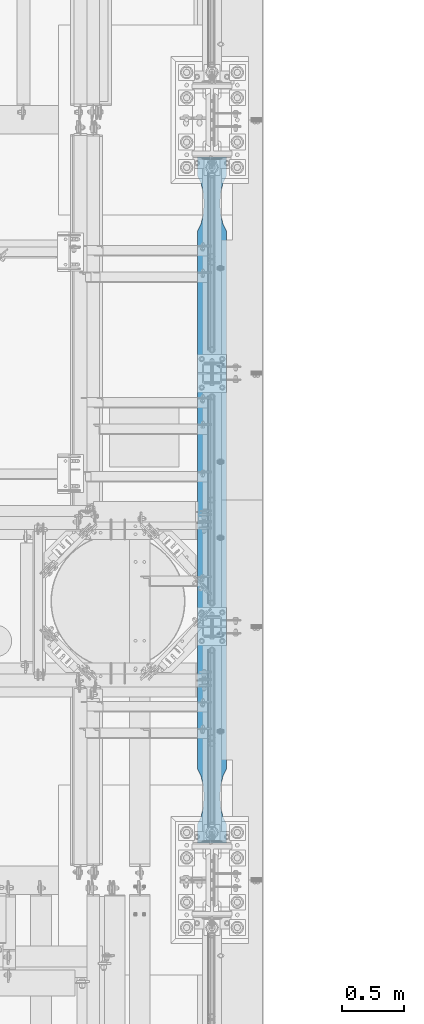
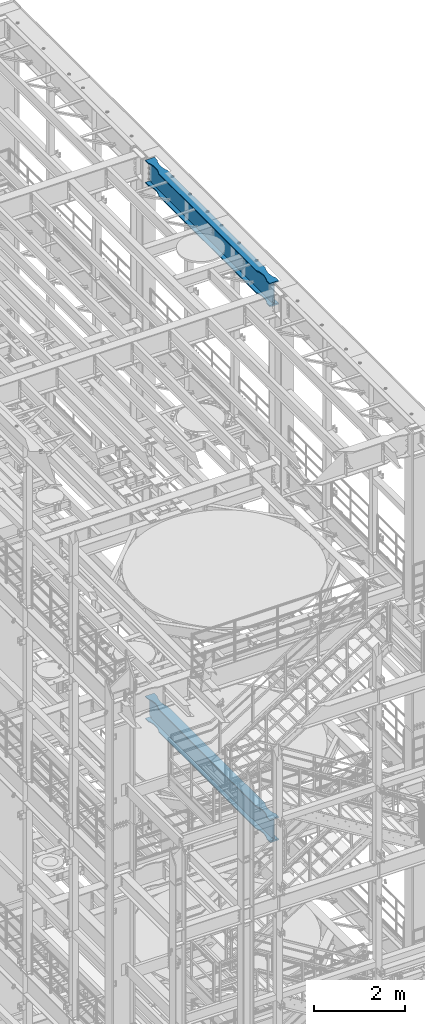
# One storey, part 1039 of 1876: 2 beams, 2 elements without a shape of their own.
"""IFC2X3 building model written with IfcOpenShell, lengths in millimetres."""

from ifc_helpers import new_model, si_unit, frame, origin_with_axes, place, context, subcontext, project, spatial, faceted_brep, material, type_object, element, aggregate, save


model = new_model("IFC2X3")

# Units and contexts
model_context = context("Model", 3, precision=1e-05, world=origin_with_axes())
body_context = subcontext(model_context, "Body", "Model", "MODEL_VIEW")
ifc_project = project(units=[si_unit("LENGTHUNIT", "METRE", prefix="MILLI"), si_unit("AREAUNIT", "SQUARE_METRE"), si_unit("VOLUMEUNIT", "CUBIC_METRE"), si_unit("MASSUNIT", "GRAM", prefix="KILO"), si_unit("TIMEUNIT", "SECOND"), si_unit("PLANEANGLEUNIT", "RADIAN"), si_unit("SOLIDANGLEUNIT", "STERADIAN"), si_unit("THERMODYNAMICTEMPERATUREUNIT", "DEGREE_CELSIUS"), si_unit("LUMINOUSINTENSITYUNIT", "LUMEN")], contexts=[model_context])

# Site, building, storey
site_placement = place(None, origin_with_axes())
site = spatial("IfcSite", under=ifc_project, at=site_placement, CompositionType="ELEMENT")
building_placement = place(site_placement, origin_with_axes())
building = spatial("IfcBuilding", under=site, at=building_placement, Name="Undefined", CompositionType="ELEMENT")
storey_placement = place(building_placement, origin_with_axes())
storey = spatial("IfcBuildingStorey", under=building, at=storey_placement, Name="Undefined", CompositionType="ELEMENT", Elevation=0.0)

# Assembly, beam
assembly_1_placement = place(storey_placement, origin_with_axes())
assembly_1 = element("IfcElementAssembly", 1, at=assembly_1_placement, inside=storey, Name="BEAM", AssemblyPlace="NOTDEFINED", PredefinedType="RIGID_FRAME")
ifc_material = material(Name="STEEL/A992")
beam_type = type_object("IfcBeamType", Name="W24X103", PredefinedType="NOTDEFINED")
beam_1_placement = place(assembly_1_placement, frame((7620.0, 1524.0, 7842.25), z_axis=(0.0, 0.0, 1.0), x_axis=(0.0, 1.0, 0.0)))
beam_1 = element("IfcBeam", 2, at=beam_1_placement, type_object=beam_type, material=ifc_material, Name="BEAM", ObjectType="W24X103", context=body_context, shape_type="Brep", body=[
    faceted_brep([(5789.6125, -7.14375000000018, -250.825000000001), (5797.55, 7.14375000000018, -250.825000000001), (5797.55, 7.14375000000018, 250.825000000001), (5789.6125, -7.14375000000018, 250.825000000001), (306.3875, -7.14375000000018, 250.825000000001), (298.45, 7.14375000000018, 250.825000000001), (298.45, 7.14375000000018, -250.825000000001), (306.3875, -7.14375000000018, -250.825000000001), (5797.55, -114.3, 285.75), (5797.55, -7.14375000000018, 285.75), (5797.55, 7.14375000000018, 285.75), (5797.55, 114.3, 285.75), (5782.88541369173, 114.29999927708, 311.150000000001), (5782.88541369173, -114.29999927708, 311.150000000001), (5641.97500876196, 114.299992330618, 311.150000000001), (5641.97500876196, 114.3, 285.75), (5592.87586146151, 88.8999957361821, 285.75), (5592.87586146151, 88.8999957361821, 311.150000000001), (5510.43685211057, 69.8863924058523, 285.75), (5510.43685211057, 69.8863924058523, 311.150000000001), (5426.0750039875, 63.5000040971918, 285.75), (5426.0750039875, 63.5000040971918, 311.150000000001), (5341.71315599965, 69.8863941921136, 285.75), (5341.71315599965, 69.8863941921136, 311.150000000001), (5259.2741470513, 88.8999992679901, 285.75), (5259.2741470513, 88.8999992679901, 311.150000000001), (5210.175, 114.3, 285.75), (5210.175, 114.3, 311.150000000001), (885.825008761703, 114.3, 285.75), (885.825008761703, 114.299990374483, 311.150000000001), (836.72586171043, 88.899989642473, 285.75), (836.72586171043, 88.899989642473, 311.150000000001), (754.286852762112, 69.8863845665965, 285.75), (754.286852762112, 69.8863845665965, 311.150000000001), (669.925004774302, 63.4999944716747, 285.75), (669.925004774302, 63.4999944716747, 311.150000000001), (585.563156651265, 69.8863827803352, 285.75), (585.563156651265, 69.8863827803352, 311.150000000001), (503.124147300347, 88.8999861106649, 285.75), (503.124147300347, 88.8999861106649, 311.150000000001), (454.024999999921, 114.3, 285.75), (454.024999999921, 114.3, 311.150000000001), (298.45, 114.3, 285.75), (313.114586308271, 114.3, 311.150000000001), (5641.97500876196, 114.299992330618, -285.75), (5641.97500876196, 114.3, -311.150000000001), (5592.87586146151, 88.8999957361821, -311.150000000001), (5592.87586146151, 88.8999957361821, -285.75), (5510.43685211057, 69.8863924058523, -311.150000000001), (5510.43685211057, 69.8863924058523, -285.75), (5426.0750039875, 63.5000040971918, -311.150000000001), (5426.0750039875, 63.5000040971918, -285.75), (5341.71315599965, 69.8863941921136, -311.150000000001), (5341.71315599965, 69.8863941921136, -285.75), (5259.2741470513, 88.8999992679901, -311.150000000001), (5259.2741470513, 88.8999992679901, -285.75), (5210.175, 114.3, -311.150000000001), (5210.175, 114.3, -285.75), (885.825008761703, 114.3, -311.150000000001), (885.825008761703, 114.299990374483, -285.75), (836.72586171043, 88.899989642473, -311.150000000001), (836.72586171043, 88.899989642473, -285.75), (754.286852762112, 69.8863845665965, -311.150000000001), (754.286852762112, 69.8863845665965, -285.75), (669.925004774302, 63.4999944716747, -311.150000000001), (669.925004774302, 63.4999944716747, -285.75), (585.563156651265, 69.8863827803352, -311.150000000001), (585.563156651265, 69.8863827803352, -285.75), (503.124147300347, 88.8999861106649, -311.150000000001), (503.124147300347, 88.8999861106649, -285.75), (454.024999999921, 114.3, -311.150000000001), (454.024999999921, 114.3, -285.75), (298.45, 114.3, -311.150000000001), (313.11459905754, 114.3, -285.75), (5641.97500876196, -114.299992330618, -285.75), (5592.87586146151, -88.8999957361821, -285.75), (5592.87586146151, -88.8999957361821, -311.150000000001), (5641.97500876196, -114.3, -311.150000000001), (5510.43685211057, -69.8863924058523, -285.75), (5510.43685211057, -69.8863924058523, -311.150000000001), (5426.0750039875, -63.5000040971918, -285.75), (5426.0750039875, -63.5000040971918, -311.150000000001), (5341.71315599965, -69.8863941921136, -285.75), (5341.71315599965, -69.8863941921136, -311.150000000001), (5259.2741470513, -88.8999992679901, -285.75), (5259.2741470513, -88.8999992679901, -311.150000000001), (5210.175, -114.3, -285.75), (5210.175, -114.3, -311.150000000001), (885.825008761703, -114.300009625517, -285.75), (885.825008761703, -114.3, -311.150000000001), (836.72586171043, -88.9000088935072, -285.75), (836.72586171043, -88.9000088935072, -311.150000000001), (754.286852762112, -69.8864038176307, -285.75), (754.286852762112, -69.8864038176307, -311.150000000001), (669.925004774302, -63.5000137227089, -285.75), (669.925004774302, -63.5000137227089, -311.150000000001), (585.563156651265, -69.8864020313695, -285.75), (585.563156651265, -69.8864020313695, -311.150000000001), (503.124147300347, -88.9000053616992, -285.75), (503.124147300347, -88.9000053616992, -311.150000000001), (454.024999999921, -114.3, -285.75), (454.024999999921, -114.3, -311.150000000001), (313.11459905754, -114.3, -285.75), (298.45, -114.3, -311.150000000001), (313.343799385621, -7.14375000000018, -285.35299987793), (313.343799385621, 7.14375000000018, -285.35299987793), (313.114599057541, 7.14375000000018, -285.75), (313.114599057541, -7.14375000000018, -285.75), (346.909996826172, -7.14375000000018, -285.35299987793), (346.909996826172, 7.14375000000018, -285.35299987793), (382.382251149282, -7.14375000000018, -269.000062630286), (382.382251149282, 7.14375000000018, -269.000062630286), (386.272459055476, -7.14375000000018, -265.703842989446), (386.272459055476, 7.14375000000018, -265.703842989446), (387.905124802588, -7.14375000000018, -260.873399528195), (387.905124802588, 7.14375000000018, -260.873399528195), (386.81238362386, -7.14375000000018, -255.89296800167), (386.81238362386, 7.14375000000018, -255.89296800167), (383.307376832887, -7.14375000000018, -252.189765486371), (383.307376832887, 7.14375000000018, -252.189765486371), (378.39451650093, -7.14375000000018, -250.825000000001), (378.39451650093, 7.14375000000018, -250.825000000001), (377.559514535493, -7.14375000000018, 250.825000000001), (377.559514535493, 7.14375000000018, 250.825000000001), (382.472374804242, -7.14375000000018, 252.189765448315), (382.472374804242, 7.14375000000018, 252.189765448315), (385.977381589376, -7.14375000000018, 255.892967871263), (385.977381589376, 7.14375000000018, 255.892967871263), (387.070122849314, -7.14375000000018, 260.873399307191), (387.070122849314, 7.14375000000018, 260.873399307191), (385.437457255921, -7.14375000000018, 265.703842745359), (385.437457255921, 7.14375000000018, 265.703842745359), (381.547249518856, -7.14375000000018, 269.000062475843), (381.547249518856, 7.14375000000018, 269.000062475843), (346.074998474121, -7.14375000000018, 285.35299987793), (346.074998474121, 7.14375000000018, 285.35299987793), (298.45, -7.14375000000018, 285.35299987793), (298.45, 7.14375000000018, 285.35299987793), (298.45, -7.14375000000018, 285.75), (298.45, 7.14375000000018, 285.75), (313.114586308271, -114.3, 311.150000000001), (298.45, -114.3, 285.75), (454.024999999921, -114.3, 285.75), (454.024999999921, -114.3, 311.150000000001), (503.124147300347, -88.9000053616992, 285.75), (503.124147300347, -88.9000053616992, 311.150000000001), (585.563156651265, -69.8864020313695, 285.75), (585.563156651265, -69.8864020313695, 311.150000000001), (669.925004774302, -63.5000137227089, 285.75), (669.925004774302, -63.5000137227089, 311.150000000001), (754.286852762112, -69.8864038176307, 285.75), (754.286852762112, -69.8864038176307, 311.150000000001), (836.72586171043, -88.9000088935072, 285.75), (836.72586171043, -88.9000088935072, 311.150000000001), (885.825008761703, -114.300009625517, 311.150000000001), (885.825008761703, -114.3, 285.75), (5210.175, -114.3, 285.75), (5210.175, -114.3, 311.150000000001), (5259.2741470513, -88.8999992679901, 285.75), (5259.2741470513, -88.8999992679901, 311.150000000001), (5341.71315599965, -69.8863941921136, 285.75), (5341.71315599965, -69.8863941921136, 311.150000000001), (5426.0750039875, -63.5000040971918, 285.75), (5426.0750039875, -63.5000040971918, 311.150000000001), (5510.43685211057, -69.8863924058523, 285.75), (5510.43685211057, -69.8863924058523, 311.150000000001), (5592.87586146151, -88.8999957361821, 285.75), (5592.87586146151, -88.8999957361821, 311.150000000001), (5641.97500876196, -114.299992330618, 311.150000000001), (5641.97500876196, -114.3, 285.75), (5797.55, -7.14375000000018, 285.35299987793), (5797.55, 7.14375000000018, 285.35299987793), (5749.92500152588, -7.14375000000018, 285.35299987793), (5749.92500152588, 7.14375000000018, 285.35299987793), (5714.45275048114, -7.14375000000018, 269.000062475843), (5714.45275048114, 7.14375000000018, 269.000062475843), (5710.56254274408, -7.14375000000018, 265.703842745359), (5710.56254274408, 7.14375000000018, 265.703842745359), (5708.92987715069, -7.14375000000018, 260.873399307191), (5708.92987715069, 7.14375000000018, 260.873399307191), (5710.02261841062, -7.14375000000018, 255.892967871263), (5710.02261841062, 7.14375000000018, 255.892967871263), (5713.52762519576, -7.14375000000018, 252.189765448315), (5713.52762519576, 7.14375000000018, 252.189765448315), (5718.44048546451, -7.14375000000018, 250.825000000001), (5718.44048546451, 7.14375000000018, 250.825000000001), (5717.60548349907, -7.14375000000018, -250.825000000001), (5717.60548349907, 7.14375000000018, -250.825000000001), (5712.69262316711, -7.14375000000018, -252.189765486371), (5712.69262316711, 7.14375000000018, -252.189765486371), (5709.18761637614, -7.14375000000018, -255.89296800167), (5709.18761637614, 7.14375000000018, -255.89296800167), (5708.09487519741, -7.14375000000018, -260.873399528195), (5708.09487519741, 7.14375000000018, -260.873399528195), (5709.72754094452, -7.14375000000018, -265.703842989446), (5709.72754094452, 7.14375000000018, -265.703842989446), (5713.61774885072, -7.14375000000018, -269.000062630286), (5713.61774885072, 7.14375000000018, -269.000062630286), (5749.09000317383, -7.14375000000018, -285.35299987793), (5749.09000317383, 7.14375000000018, -285.35299987793), (5782.65620061438, -7.14375000000018, -285.35299987793), (5782.65620061438, 7.14375000000018, -285.35299987793), (5782.88540094246, 7.14375000000018, -285.75), (5782.88540094246, 114.299999277079, -285.75), (5797.55, 114.3, -311.150000000001), (5797.55, -114.3, -311.150000000001), (5782.88540094246, -114.299999277079, -285.75), (5782.88540094246, -7.14375000000018, -285.75)], [[[0, 1, 2, 3]], [[4, 5, 6, 7]], [[8, 9, 10, 11, 12, 13]], [[14, 15, 16, 17]], [[17, 16, 18, 19]], [[19, 18, 20, 21]], [[21, 20, 22, 23]], [[23, 22, 24, 25]], [[25, 24, 26, 27]], [[27, 26, 28, 29]], [[29, 28, 30, 31]], [[31, 30, 32, 33]], [[33, 32, 34, 35]], [[35, 34, 36, 37]], [[37, 36, 38, 39]], [[39, 38, 40, 41]], [[41, 40, 42, 43]], [[44, 45, 46, 47]], [[47, 46, 48, 49]], [[49, 48, 50, 51]], [[51, 50, 52, 53]], [[53, 52, 54, 55]], [[55, 54, 56, 57]], [[57, 56, 58, 59]], [[59, 58, 60, 61]], [[61, 60, 62, 63]], [[63, 62, 64, 65]], [[65, 64, 66, 67]], [[67, 66, 68, 69]], [[69, 68, 70, 71]], [[71, 70, 72, 73]], [[74, 75, 76, 77]], [[78, 79, 76, 75]], [[80, 81, 79, 78]], [[82, 83, 81, 80]], [[84, 85, 83, 82]], [[86, 87, 85, 84]], [[87, 86, 88, 89]], [[88, 90, 91, 89]], [[92, 93, 91, 90]], [[94, 95, 93, 92]], [[96, 97, 95, 94]], [[98, 99, 97, 96]], [[100, 101, 99, 98]], [[101, 100, 102, 103]], [[104, 105, 106, 73, 72, 103, 102, 107]], [[108, 109, 105, 104]], [[110, 111, 109, 108]], [[112, 113, 111, 110]], [[114, 115, 113, 112]], [[116, 117, 115, 114]], [[118, 119, 117, 116]], [[120, 121, 119, 118]], [[121, 120, 7, 6]], [[122, 123, 5, 4]], [[124, 125, 123, 122]], [[126, 127, 125, 124]], [[128, 129, 127, 126]], [[130, 131, 129, 128]], [[132, 133, 131, 130]], [[134, 135, 133, 132]], [[135, 134, 136, 137]], [[137, 136, 138, 139]], [[140, 43, 42, 139, 138, 141]], [[142, 143, 140, 141]], [[143, 142, 144, 145]], [[145, 144, 146, 147]], [[147, 146, 148, 149]], [[149, 148, 150, 151]], [[151, 150, 152, 153]], [[154, 153, 152, 155]], [[156, 157, 154, 155]], [[157, 156, 158, 159]], [[159, 158, 160, 161]], [[161, 160, 162, 163]], [[163, 162, 164, 165]], [[165, 164, 166, 167]], [[168, 167, 166, 169]], [[168, 169, 8, 13]], [[14, 17, 19, 21, 23, 25, 27, 29, 31, 33, 35, 37, 39, 41, 43, 140, 143, 145, 147, 149, 151, 153, 154, 157, 159, 161, 163, 165, 167, 168, 13, 12]], [[15, 14, 12, 11]], [[139, 42, 40, 38, 36, 34, 32, 30, 28, 26, 24, 22, 20, 18, 16, 15, 11, 10]], [[170, 171, 10, 9]], [[172, 173, 171, 170]], [[174, 175, 173, 172]], [[176, 177, 175, 174]], [[178, 179, 177, 176]], [[180, 181, 179, 178]], [[182, 183, 181, 180]], [[184, 185, 183, 182]], [[185, 184, 3, 2]], [[186, 187, 1, 0]], [[188, 189, 187, 186]], [[190, 191, 189, 188]], [[192, 193, 191, 190]], [[194, 195, 193, 192]], [[196, 197, 195, 194]], [[198, 199, 197, 196]], [[199, 198, 200, 201]], [[106, 105, 109, 111, 113, 115, 117, 119, 121, 6, 5, 123, 125, 127, 129, 131, 133, 135, 137, 139, 10, 171, 173, 175, 177, 179, 181, 183, 185, 2, 1, 187, 189, 191, 193, 195, 197, 199, 201, 202]], [[44, 47, 49, 51, 53, 55, 57, 59, 61, 63, 65, 67, 69, 71, 73, 106, 202, 203]], [[45, 44, 203, 204]], [[77, 76, 79, 81, 83, 85, 87, 89, 91, 93, 95, 97, 99, 101, 103, 72, 70, 68, 66, 64, 62, 60, 58, 56, 54, 52, 50, 48, 46, 45, 204, 205]], [[74, 77, 205, 206]], [[107, 102, 100, 98, 96, 94, 92, 90, 88, 86, 84, 82, 80, 78, 75, 74, 206, 207]], [[205, 204, 203, 202, 201, 200, 207, 206]], [[184, 182, 180, 178, 176, 174, 172, 170, 9, 138, 136, 134, 132, 130, 128, 126, 124, 122, 4, 7, 120, 118, 116, 114, 112, 110, 108, 104, 107, 207, 200, 198, 196, 194, 192, 190, 188, 186, 0, 3]], [[169, 166, 164, 162, 160, 158, 156, 155, 152, 150, 148, 146, 144, 142, 141, 138, 9, 8]]]),
])
aggregate(assembly_1, [beam_1])

assembly_2_placement = place(storey_placement, origin_with_axes())
assembly_2 = element("IfcElementAssembly", 3, at=assembly_2_placement, inside=storey, Name="BEAM", AssemblyPlace="NOTDEFINED", PredefinedType="RIGID_FRAME")
beam_2_placement = place(assembly_2_placement, frame((7620.0, 1524.0, 22244.05), z_axis=(0.0, 0.0, 1.0), x_axis=(0.0, 1.0, 0.0)))
beam_2 = element("IfcBeam", 4, at=beam_2_placement, type_object=beam_type, material=ifc_material, Name="BEAM", ObjectType="W24X103", context=body_context, shape_type="Brep", body=[
    faceted_brep([(5789.6125, -7.14375000000018, -250.825000000001), (5797.55, 7.14375000000018, -250.825000000001), (5797.55, 7.14375000000018, 250.825000000001), (5789.6125, -7.14375000000018, 250.825000000001), (306.3875, -7.14375000000018, 250.825000000001), (298.45, 7.14375000000018, 250.825000000001), (298.45, 7.14375000000018, -250.825000000001), (306.3875, -7.14375000000018, -250.825000000001), (5510.43685211057, -69.8863924058523, -285.75), (5510.43685211057, -69.8863924058523, -311.150000000001), (5592.87586146151, -88.8999957361821, -311.150000000001), (5592.87586146151, -88.8999957361821, -285.75), (5426.0750039875, -63.5000040971918, -285.75), (5426.0750039875, -63.5000040971918, -311.150000000001), (5341.71315599965, -69.8863941921136, -285.75), (5341.71315599965, -69.8863941921136, -311.150000000001), (5259.2741470513, -88.8999992679901, -285.75), (5259.2741470513, -88.8999992679901, -311.150000000001), (5210.175, -114.3, -285.75), (5210.175, -114.3, -311.150000000001), (885.825008761703, -114.300009625517, -285.75), (885.825008761703, -114.3, -311.150000000001), (5210.175, -114.3, 285.75), (5210.175, -114.3, 311.150000000001), (885.825008761703, -114.300009625517, 311.150000000001), (885.825008761703, -114.3, 285.75), (5259.2741470513, -88.8999992679901, 285.75), (5259.2741470513, -88.8999992679901, 311.150000000001), (5341.71315599965, -69.8863941921136, 285.75), (5341.71315599965, -69.8863941921136, 311.150000000001), (5426.0750039875, -63.5000040971918, 285.75), (5426.0750039875, -63.5000040971918, 311.150000000001), (5510.43685211057, -69.8863924058523, 285.75), (5510.43685211057, -69.8863924058523, 311.150000000001), (5592.87586146151, -88.8999957361821, 285.75), (5592.87586146151, -88.8999957361821, 311.150000000001), (5641.97500876196, -114.299992330618, 311.150000000001), (5641.97500876196, -114.3, 285.75), (5797.55, -114.3, 285.75), (5782.88541369173, -114.29999927708, 311.150000000001), (5749.09000317383, -7.14375000000018, -285.35299987793), (5749.09000317383, 7.14375000000018, -285.35299987793), (5713.61774885072, 7.14375000000018, -269.000062630286), (5713.61774885072, -7.14375000000018, -269.000062630286), (5709.72754094452, 7.14375000000018, -265.703842989446), (5709.72754094452, -7.14375000000018, -265.703842989446), (5708.09487519741, 7.14375000000018, -260.873399528195), (5708.09487519741, -7.14375000000018, -260.873399528195), (5709.18761637614, 7.14375000000018, -255.89296800167), (5709.18761637614, -7.14375000000018, -255.89296800167), (5712.69262316711, 7.14375000000018, -252.189765486371), (5712.69262316711, -7.14375000000018, -252.189765486371), (5717.60548349907, 7.14375000000018, -250.825000000001), (5717.60548349907, -7.14375000000018, -250.825000000001), (5718.44048546451, 7.14375000000018, 250.825000000001), (5718.44048546451, -7.14375000000018, 250.825000000001), (5713.52762519576, 7.14375000000018, 252.189765448315), (5713.52762519576, -7.14375000000018, 252.189765448315), (5710.02261841062, 7.14375000000018, 255.892967871263), (5710.02261841062, -7.14375000000018, 255.892967871263), (5708.92987715069, 7.14375000000018, 260.873399307191), (5708.92987715069, -7.14375000000018, 260.873399307191), (5710.56254274408, 7.14375000000018, 265.703842745359), (5710.56254274408, -7.14375000000018, 265.703842745359), (5714.45275048114, 7.14375000000018, 269.000062475843), (5714.45275048114, -7.14375000000018, 269.000062475843), (5749.92500152588, 7.14375000000018, 285.35299987793), (5749.92500152588, -7.14375000000018, 285.35299987793), (5797.55, 7.14375000000018, 285.35299987793), (5797.55, -7.14375000000018, 285.35299987793), (5797.55, 7.14375000000018, 285.75), (5797.55, -7.14375000000018, 285.75), (5210.175, 114.3, 311.150000000001), (5210.175, 114.3, 285.75), (885.825008761703, 114.3, 285.75), (885.825008761703, 114.299990374483, 311.150000000001), (5259.2741470513, 88.8999992679901, 311.150000000001), (5259.2741470513, 88.8999992679901, 285.75), (5341.71315599965, 69.8863941921136, 311.150000000001), (5341.71315599965, 69.8863941921136, 285.75), (5426.0750039875, 63.5000040971918, 311.150000000001), (5426.0750039875, 63.5000040971918, 285.75), (5510.43685211057, 69.8863924058523, 311.150000000001), (5510.43685211057, 69.8863924058523, 285.75), (5592.87586146151, 88.8999957361821, 311.150000000001), (5592.87586146151, 88.8999957361821, 285.75), (5641.97500876196, 114.299992330618, 311.150000000001), (5641.97500876196, 114.3, 285.75), (5782.88541369173, 114.29999927708, 311.150000000001), (5797.55, 114.3, 285.75), (298.45, 7.14375000000018, 285.75), (298.45, 114.3, 285.75), (454.024999999921, 114.3, 285.75), (503.124147300347, 88.8999861106649, 285.75), (585.563156651265, 69.8863827803352, 285.75), (669.925004774302, 63.4999944716747, 285.75), (754.286852762112, 69.8863845665965, 285.75), (836.72586171043, 88.899989642473, 285.75), (454.024999999921, 114.3, 311.150000000001), (313.114586308271, 114.3, 311.150000000001), (503.124147300347, 88.8999861106649, 311.150000000001), (585.563156651265, 69.8863827803352, 311.150000000001), (669.925004774302, 63.4999944716747, 311.150000000001), (754.286852762112, 69.8863845665965, 311.150000000001), (836.72586171043, 88.899989642473, 311.150000000001), (313.114586308271, -114.3, 311.150000000001), (454.024999999921, -114.3, 311.150000000001), (503.124147300347, -88.9000053616992, 311.150000000001), (585.563156651265, -69.8864020313695, 311.150000000001), (669.925004774302, -63.5000137227089, 311.150000000001), (754.286852762112, -69.8864038176307, 311.150000000001), (836.72586171043, -88.9000088935072, 311.150000000001), (454.024999999921, -114.3, 285.75), (298.45, -114.3, 285.75), (503.124147300347, -88.9000053616992, 285.75), (585.563156651265, -69.8864020313695, 285.75), (669.925004774302, -63.5000137227089, 285.75), (754.286852762112, -69.8864038176307, 285.75), (836.72586171043, -88.9000088935072, 285.75), (298.45, -7.14375000000018, 285.75), (298.45, 7.14375000000018, 285.35299987793), (298.45, -7.14375000000018, 285.35299987793), (346.074998474121, 7.14375000000018, 285.35299987793), (346.074998474121, -7.14375000000018, 285.35299987793), (381.547249518856, 7.14375000000018, 269.000062475843), (381.547249518856, -7.14375000000018, 269.000062475843), (385.437457255921, 7.14375000000018, 265.703842745359), (385.437457255921, -7.14375000000018, 265.703842745359), (387.070122849314, 7.14375000000018, 260.873399307191), (387.070122849314, -7.14375000000018, 260.873399307191), (385.977381589376, 7.14375000000018, 255.892967871263), (385.977381589376, -7.14375000000018, 255.892967871263), (382.472374804242, 7.14375000000018, 252.189765448315), (382.472374804242, -7.14375000000018, 252.189765448315), (377.559514535493, 7.14375000000018, 250.825000000001), (377.559514535493, -7.14375000000018, 250.825000000001), (378.39451650093, 7.14375000000018, -250.825000000001), (378.39451650093, -7.14375000000018, -250.825000000001), (383.307376832887, 7.14375000000018, -252.189765486371), (383.307376832887, -7.14375000000018, -252.189765486371), (386.81238362386, 7.14375000000018, -255.89296800167), (386.81238362386, -7.14375000000018, -255.89296800167), (387.905124802588, 7.14375000000018, -260.873399528195), (387.905124802588, -7.14375000000018, -260.873399528195), (386.272459055476, 7.14375000000018, -265.703842989446), (386.272459055476, -7.14375000000018, -265.703842989446), (382.382251149282, 7.14375000000018, -269.000062630286), (382.382251149282, -7.14375000000018, -269.000062630286), (346.909996826172, 7.14375000000018, -285.35299987793), (346.909996826172, -7.14375000000018, -285.35299987793), (313.343799385621, 7.14375000000018, -285.35299987793), (313.343799385621, -7.14375000000018, -285.35299987793), (313.114599057541, -7.14375000000018, -285.75), (5782.88540094246, -7.14375000000018, -285.75), (5782.65620061438, -7.14375000000018, -285.35299987793), (5782.65620061438, 7.14375000000018, -285.35299987793), (313.114599057541, 7.14375000000018, -285.75), (5782.88540094246, 7.14375000000018, -285.75), (313.11459905754, 114.3, -285.75), (298.45, 114.3, -311.150000000001), (298.45, -114.3, -311.150000000001), (313.11459905754, -114.3, -285.75), (454.024999999921, -114.3, -311.150000000001), (454.024999999921, -114.3, -285.75), (503.124147300347, -88.9000053616992, -311.150000000001), (503.124147300347, -88.9000053616992, -285.75), (585.563156651265, -69.8864020313695, -311.150000000001), (585.563156651265, -69.8864020313695, -285.75), (669.925004774302, -63.5000137227089, -311.150000000001), (669.925004774302, -63.5000137227089, -285.75), (754.286852762112, -69.8864038176307, -311.150000000001), (754.286852762112, -69.8864038176307, -285.75), (836.72586171043, -88.9000088935072, -311.150000000001), (836.72586171043, -88.9000088935072, -285.75), (5641.97500876196, -114.299992330618, -285.75), (5782.88540094246, -114.299999277079, -285.75), (5797.55, -114.3, -311.150000000001), (5797.55, 114.3, -311.150000000001), (5782.88540094246, 114.299999277079, -285.75), (5641.97500876196, 114.3, -311.150000000001), (5641.97500876196, 114.299992330618, -285.75), (5592.87586146151, 88.8999957361821, -311.150000000001), (5592.87586146151, 88.8999957361821, -285.75), (5510.43685211057, 69.8863924058523, -311.150000000001), (5510.43685211057, 69.8863924058523, -285.75), (5426.0750039875, 63.5000040971918, -311.150000000001), (5426.0750039875, 63.5000040971918, -285.75), (5341.71315599965, 69.8863941921136, -311.150000000001), (5341.71315599965, 69.8863941921136, -285.75), (5259.2741470513, 88.8999992679901, -311.150000000001), (5259.2741470513, 88.8999992679901, -285.75), (5210.175, 114.3, -311.150000000001), (5210.175, 114.3, -285.75), (885.825008761703, 114.3, -311.150000000001), (885.825008761703, 114.299990374483, -285.75), (836.72586171043, 88.899989642473, -285.75), (754.286852762112, 69.8863845665965, -285.75), (669.925004774302, 63.4999944716747, -285.75), (585.563156651265, 69.8863827803352, -285.75), (503.124147300347, 88.8999861106649, -285.75), (454.024999999921, 114.3, -285.75), (454.024999999921, 114.3, -311.150000000001), (503.124147300347, 88.8999861106649, -311.150000000001), (585.563156651265, 69.8863827803352, -311.150000000001), (669.925004774302, 63.4999944716747, -311.150000000001), (754.286852762112, 69.8863845665965, -311.150000000001), (836.72586171043, 88.899989642473, -311.150000000001), (5641.97500876196, -114.3, -311.150000000001)], [[[0, 1, 2, 3]], [[4, 5, 6, 7]], [[8, 9, 10, 11]], [[12, 13, 9, 8]], [[14, 15, 13, 12]], [[16, 17, 15, 14]], [[18, 19, 17, 16]], [[19, 18, 20, 21]], [[22, 23, 24, 25]], [[23, 22, 26, 27]], [[27, 26, 28, 29]], [[29, 28, 30, 31]], [[31, 30, 32, 33]], [[33, 32, 34, 35]], [[36, 35, 34, 37]], [[36, 37, 38, 39]], [[40, 41, 42, 43]], [[43, 42, 44, 45]], [[45, 44, 46, 47]], [[47, 46, 48, 49]], [[49, 48, 50, 51]], [[51, 50, 52, 53]], [[53, 52, 1, 0]], [[54, 55, 3, 2]], [[55, 54, 56, 57]], [[57, 56, 58, 59]], [[59, 58, 60, 61]], [[61, 60, 62, 63]], [[63, 62, 64, 65]], [[65, 64, 66, 67]], [[67, 66, 68, 69]], [[69, 68, 70, 71]], [[72, 73, 74, 75]], [[76, 77, 73, 72]], [[78, 79, 77, 76]], [[80, 81, 79, 78]], [[82, 83, 81, 80]], [[84, 85, 83, 82]], [[86, 87, 85, 84]], [[87, 86, 88, 89]], [[38, 71, 70, 89, 88, 39]], [[90, 91, 92, 93, 94, 95, 96, 97, 74, 73, 77, 79, 81, 83, 85, 87, 89, 70]], [[98, 92, 91, 99]], [[100, 93, 92, 98]], [[101, 94, 93, 100]], [[102, 95, 94, 101]], [[103, 96, 95, 102]], [[104, 97, 96, 103]], [[75, 74, 97, 104]], [[86, 84, 82, 80, 78, 76, 72, 75, 104, 103, 102, 101, 100, 98, 99, 105, 106, 107, 108, 109, 110, 111, 24, 23, 27, 29, 31, 33, 35, 36, 39, 88]], [[112, 106, 105, 113]], [[106, 112, 114, 107]], [[107, 114, 115, 108]], [[108, 115, 116, 109]], [[109, 116, 117, 110]], [[110, 117, 118, 111]], [[24, 111, 118, 25]], [[37, 34, 32, 30, 28, 26, 22, 25, 118, 117, 116, 115, 114, 112, 113, 119, 71, 38]], [[105, 99, 91, 90, 119, 113]], [[120, 121, 119, 90]], [[122, 123, 121, 120]], [[123, 122, 124, 125]], [[125, 124, 126, 127]], [[127, 126, 128, 129]], [[129, 128, 130, 131]], [[131, 130, 132, 133]], [[133, 132, 134, 135]], [[135, 134, 5, 4]], [[136, 137, 7, 6]], [[137, 136, 138, 139]], [[139, 138, 140, 141]], [[141, 140, 142, 143]], [[143, 142, 144, 145]], [[145, 144, 146, 147]], [[147, 146, 148, 149]], [[149, 148, 150, 151]], [[55, 57, 59, 61, 63, 65, 67, 69, 71, 119, 121, 123, 125, 127, 129, 131, 133, 135, 4, 7, 137, 139, 141, 143, 145, 147, 149, 151, 152, 153, 154, 40, 43, 45, 47, 49, 51, 53, 0, 3]], [[41, 40, 154, 155]], [[156, 150, 148, 146, 144, 142, 140, 138, 136, 6, 5, 134, 132, 130, 128, 126, 124, 122, 120, 90, 70, 68, 66, 64, 62, 60, 58, 56, 54, 2, 1, 52, 50, 48, 46, 44, 42, 41, 155, 157]], [[151, 150, 156, 158, 159, 160, 161, 152]], [[162, 163, 161, 160]], [[163, 162, 164, 165]], [[165, 164, 166, 167]], [[167, 166, 168, 169]], [[169, 168, 170, 171]], [[171, 170, 172, 173]], [[20, 173, 172, 21]], [[152, 161, 163, 165, 167, 169, 171, 173, 20, 18, 16, 14, 12, 8, 11, 174, 175, 153]], [[176, 177, 178, 157, 155, 154, 153, 175]], [[179, 180, 178, 177]], [[180, 179, 181, 182]], [[182, 181, 183, 184]], [[184, 183, 185, 186]], [[186, 185, 187, 188]], [[188, 187, 189, 190]], [[190, 189, 191, 192]], [[192, 191, 193, 194]], [[180, 182, 184, 186, 188, 190, 192, 194, 195, 196, 197, 198, 199, 200, 158, 156, 157, 178]], [[200, 201, 159, 158]], [[199, 202, 201, 200]], [[198, 203, 202, 199]], [[197, 204, 203, 198]], [[196, 205, 204, 197]], [[195, 206, 205, 196]], [[194, 193, 206, 195]], [[207, 10, 9, 13, 15, 17, 19, 21, 172, 170, 168, 166, 164, 162, 160, 159, 201, 202, 203, 204, 205, 206, 193, 191, 189, 187, 185, 183, 181, 179, 177, 176]], [[174, 11, 10, 207]], [[174, 207, 176, 175]]]),
])
aggregate(assembly_2, [beam_2])

save(model, "model.ifc")
